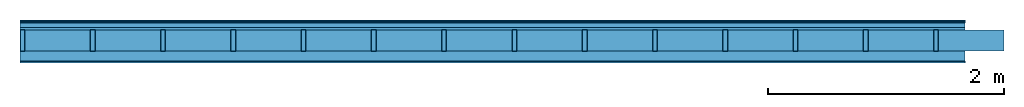
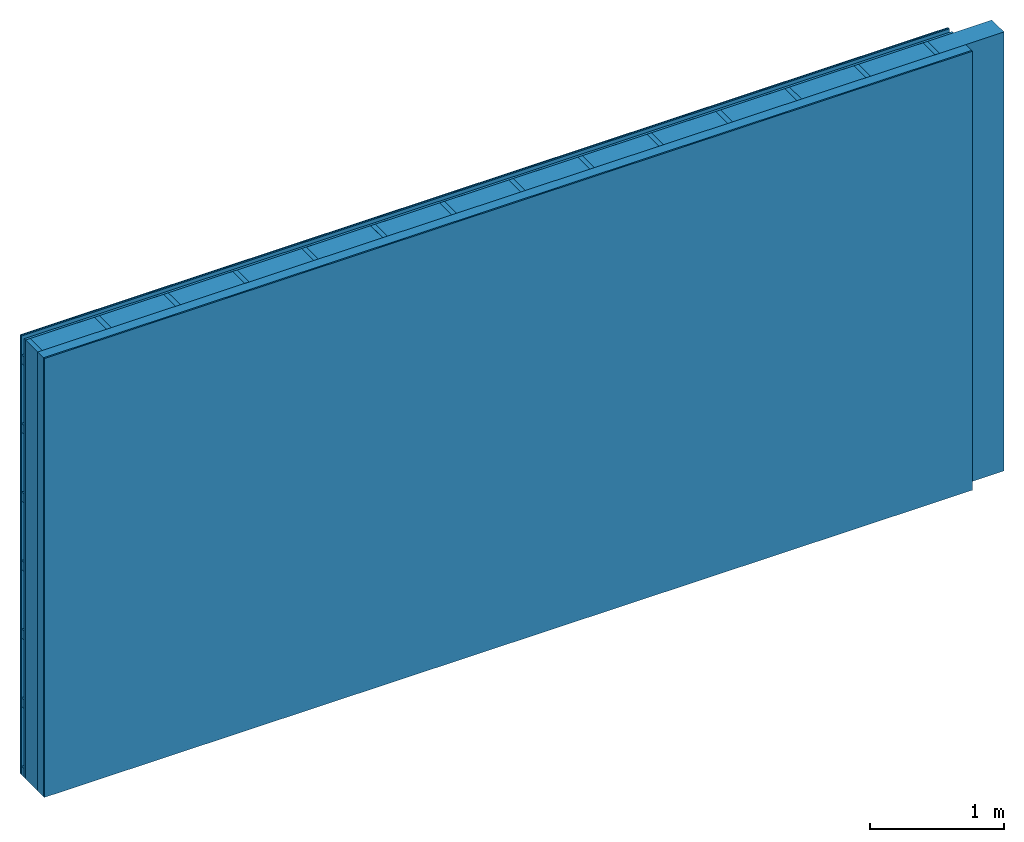
# One storey: 5 plates, 3 members, 1 element without a shape of its own.
"""IFC4 building model written with IfcOpenShell, lengths in metres."""

from ifc_helpers import new_model, si_unit, derived_unit, direction, frame, frame_2d, origin, origin_with_axes, place, context, project, spatial, rectangle, extrude, material, layer, layer_set, type_object, element, aggregate, save


model = new_model("IFC4")

# Units and contexts
plan_context = context("Plan", 3, precision=1e-05, world=origin(), true_north=direction((0.0, 1.0)))
model_context = context("Model", 3, precision=1e-05, world=origin(), true_north=direction((0.0, 1.0)))
ifc_project = project(units=[si_unit("LENGTHUNIT", "METRE"), derived_unit("SOUNDPRESSUREUNIT", [(si_unit("PRESSUREUNIT", "PASCAL", prefix="MICRO"), 0)]), si_unit("ENERGYUNIT", "JOULE", prefix="MEGA"), si_unit("MASSUNIT", "GRAM", prefix="KILO"), derived_unit("THERMALTRANSMITTANCEUNIT", [(si_unit("POWERUNIT", "WATT"), 1), (si_unit("AREAUNIT", "SQUARE_METRE"), -1), (si_unit("THERMODYNAMICTEMPERATUREUNIT", "KELVIN"), -1)]), derived_unit("AREADENSITYUNIT", [(si_unit("MASSUNIT", "GRAM", prefix="KILO"), 1), (si_unit("AREAUNIT", "SQUARE_METRE"), -1)]), derived_unit("USERDEFINED", [(si_unit("ENERGYUNIT", "JOULE", prefix="MEGA"), 1), (si_unit("AREAUNIT", "SQUARE_METRE"), -1)])], contexts=[plan_context, model_context])

# Site, building, storey
site = spatial("IfcSite", under=ifc_project)
building_placement = place(None, origin())
building = spatial("IfcBuilding", under=site, at=building_placement)
storey_placement = place(building_placement, origin())
storey = spatial("IfcBuildingStorey", under=building, at=storey_placement)

# Wall, members, plates
ifc_material_1 = material(Category="04.011")
ifc_layer_1 = layer(ifc_material_1, 0.01, Name="Surface 1")
ifc_material_2 = material(Name="mineral, cement-based building board", Category="03.003")
ifc_layer_2 = layer(ifc_material_2, 0.013, Name="Cover 1st layer")
ifc_layer_3 = layer(None, 0.04, Name="Battens / profiles (ventilation)")
ifc_material_3 = material(Category="10.009")
ifc_layer_4 = layer(ifc_material_3, 0.02, Name="outside 1st layer")
ifc_material_4 = material(Name="of the art")
ifc_layer_5 = layer(ifc_material_4, 0.0, Name="Bond")
ifc_layer_6 = layer(None, 0.18, Name="Support")
ifc_layer_7 = layer(ifc_material_4, 0.0, Name="Bond")
ifc_material_5 = material(Name="Solid timber panel")
ifc_layer_8 = layer(ifc_material_5, 0.087, Name="1st layer")
ifc_material_6 = material(Name="Plasterboard type A", Category="03.008")
ifc_layer_9 = layer(ifc_material_6, 0.0125, Name="Covering 1st layer")
ifc_material_7 = material(Name="joints", Category="04.017")
ifc_layer_10 = layer(ifc_material_7, 0.0, Name="Surface")
ifc_layer_set = layer_set([ifc_layer_1, ifc_layer_2, ifc_layer_3, ifc_layer_4, ifc_layer_5, ifc_layer_6, ifc_layer_7, ifc_layer_8, ifc_layer_9, ifc_layer_10])
wall_type = type_object("IfcWallType", Name="D0975", PredefinedType="NOTDEFINED", material=ifc_layer_set)
wall_placement = place(None, frame((0.0, 0.0, 0.0), z_axis=(0.0, -1.0, 0.0), x_axis=(1.0, 0.0, 0.0)))
wall = element("IfcWall", 1, at=wall_placement, inside=storey, type_object=wall_type, material=ifc_layer_set, Name="Wall #1")
ifc_material_8 = material()
member_1_placement = place(wall_placement, origin())
member_1 = element("IfcMember", 2, at=member_1_placement, material=ifc_material_8, Name="Battens / profiles (ventilation)", context=plan_context, shape_type="SweptSolid", body=[
    extrude(rectangle(XDim=0.08, YDim=0.04, at=frame_2d((0.04, 0.02), x_axis=(1.0, 0.0))), frame((0.0, 0.0, 0.023), z_axis=(1.0, 0.0, 0.0), x_axis=(0.0, 1.0, 0.0)), (0.0, 0.0, 1.0), 8.0),
    extrude(rectangle(XDim=0.08, YDim=0.04, at=frame_2d((0.04, 0.02), x_axis=(1.0, 0.0))), frame((0.0, 0.625, 0.023), z_axis=(1.0, 0.0, 0.0), x_axis=(0.0, 1.0, 0.0)), (0.0, 0.0, 1.0), 8.0),
    extrude(rectangle(XDim=0.08, YDim=0.04, at=frame_2d((0.04, 0.02), x_axis=(1.0, 0.0))), frame((0.0, 1.25, 0.023), z_axis=(1.0, 0.0, 0.0), x_axis=(0.0, 1.0, 0.0)), (0.0, 0.0, 1.0), 8.0),
    extrude(rectangle(XDim=0.08, YDim=0.04, at=frame_2d((0.04, 0.02), x_axis=(1.0, 0.0))), frame((0.0, 1.875, 0.023), z_axis=(1.0, 0.0, 0.0), x_axis=(0.0, 1.0, 0.0)), (0.0, 0.0, 1.0), 8.0),
    extrude(rectangle(XDim=0.08, YDim=0.04, at=frame_2d((0.04, 0.02), x_axis=(1.0, 0.0))), frame((0.0, 2.5, 0.023), z_axis=(1.0, 0.0, 0.0), x_axis=(0.0, 1.0, 0.0)), (0.0, 0.0, 1.0), 8.0),
    extrude(rectangle(XDim=0.08, YDim=0.04, at=frame_2d((0.04, 0.02), x_axis=(1.0, 0.0))), frame((0.0, 3.125, 0.023), z_axis=(1.0, 0.0, 0.0), x_axis=(0.0, 1.0, 0.0)), (0.0, 0.0, 1.0), 8.0),
    extrude(rectangle(XDim=0.08, YDim=0.04, at=frame_2d((0.04, 0.02), x_axis=(1.0, 0.0))), frame((0.0, 3.75, 0.023), z_axis=(1.0, 0.0, 0.0), x_axis=(0.0, 1.0, 0.0)), (0.0, 0.0, 1.0), 8.0),
])
ifc_material_9 = material()
member_2_placement = place(wall_placement, origin())
member_2 = element("IfcMember", 3, at=member_2_placement, material=ifc_material_9, Name="Support", context=plan_context, shape_type="SweptSolid", body=[
    extrude(rectangle(XDim=0.04, YDim=0.18, at=frame_2d((0.02, 0.09), x_axis=(1.0, 0.0))), frame((0.0, 4.0, 0.083), z_axis=(0.0, -1.0, 0.0), x_axis=(1.0, 0.0, 0.0)), (0.0, 0.0, 1.0), 4.0),
    extrude(rectangle(XDim=0.04, YDim=0.18, at=frame_2d((0.02, 0.09), x_axis=(1.0, 0.0))), frame((0.595, 4.0, 0.083), z_axis=(0.0, -1.0, 0.0), x_axis=(1.0, 0.0, 0.0)), (0.0, 0.0, 1.0), 4.0),
    extrude(rectangle(XDim=0.04, YDim=0.18, at=frame_2d((0.02, 0.09), x_axis=(1.0, 0.0))), frame((1.19, 4.0, 0.083), z_axis=(0.0, -1.0, 0.0), x_axis=(1.0, 0.0, 0.0)), (0.0, 0.0, 1.0), 4.0),
    extrude(rectangle(XDim=0.04, YDim=0.18, at=frame_2d((0.02, 0.09), x_axis=(1.0, 0.0))), frame((1.785, 4.0, 0.083), z_axis=(0.0, -1.0, 0.0), x_axis=(1.0, 0.0, 0.0)), (0.0, 0.0, 1.0), 4.0),
    extrude(rectangle(XDim=0.04, YDim=0.18, at=frame_2d((0.02, 0.09), x_axis=(1.0, 0.0))), frame((2.38, 4.0, 0.083), z_axis=(0.0, -1.0, 0.0), x_axis=(1.0, 0.0, 0.0)), (0.0, 0.0, 1.0), 4.0),
    extrude(rectangle(XDim=0.04, YDim=0.18, at=frame_2d((0.02, 0.09), x_axis=(1.0, 0.0))), frame((2.975, 4.0, 0.083), z_axis=(0.0, -1.0, 0.0), x_axis=(1.0, 0.0, 0.0)), (0.0, 0.0, 1.0), 4.0),
    extrude(rectangle(XDim=0.04, YDim=0.18, at=frame_2d((0.02, 0.09), x_axis=(1.0, 0.0))), frame((3.57, 4.0, 0.083), z_axis=(0.0, -1.0, 0.0), x_axis=(1.0, 0.0, 0.0)), (0.0, 0.0, 1.0), 4.0),
    extrude(rectangle(XDim=0.04, YDim=0.18, at=frame_2d((0.02, 0.09), x_axis=(1.0, 0.0))), frame((4.165, 4.0, 0.083), z_axis=(0.0, -1.0, 0.0), x_axis=(1.0, 0.0, 0.0)), (0.0, 0.0, 1.0), 4.0),
    extrude(rectangle(XDim=0.04, YDim=0.18, at=frame_2d((0.02, 0.09), x_axis=(1.0, 0.0))), frame((4.76, 4.0, 0.083), z_axis=(0.0, -1.0, 0.0), x_axis=(1.0, 0.0, 0.0)), (0.0, 0.0, 1.0), 4.0),
    extrude(rectangle(XDim=0.04, YDim=0.18, at=frame_2d((0.02, 0.09), x_axis=(1.0, 0.0))), frame((5.355, 4.0, 0.083), z_axis=(0.0, -1.0, 0.0), x_axis=(1.0, 0.0, 0.0)), (0.0, 0.0, 1.0), 4.0),
    extrude(rectangle(XDim=0.04, YDim=0.18, at=frame_2d((0.02, 0.09), x_axis=(1.0, 0.0))), frame((5.95, 4.0, 0.083), z_axis=(0.0, -1.0, 0.0), x_axis=(1.0, 0.0, 0.0)), (0.0, 0.0, 1.0), 4.0),
    extrude(rectangle(XDim=0.04, YDim=0.18, at=frame_2d((0.02, 0.09), x_axis=(1.0, 0.0))), frame((6.545, 4.0, 0.083), z_axis=(0.0, -1.0, 0.0), x_axis=(1.0, 0.0, 0.0)), (0.0, 0.0, 1.0), 4.0),
    extrude(rectangle(XDim=0.04, YDim=0.18, at=frame_2d((0.02, 0.09), x_axis=(1.0, 0.0))), frame((7.14, 4.0, 0.083), z_axis=(0.0, -1.0, 0.0), x_axis=(1.0, 0.0, 0.0)), (0.0, 0.0, 1.0), 4.0),
    extrude(rectangle(XDim=0.04, YDim=0.18, at=frame_2d((0.02, 0.09), x_axis=(1.0, 0.0))), frame((7.735, 4.0, 0.083), z_axis=(0.0, -1.0, 0.0), x_axis=(1.0, 0.0, 0.0)), (0.0, 0.0, 1.0), 4.0),
])
ifc_material_10 = material()
member_3_placement = place(wall_placement, origin())
member_3 = element("IfcMember", 4, at=member_3_placement, material=ifc_material_10, Name="Cavity", context=plan_context, shape_type="SweptSolid", body=[
    extrude(rectangle(XDim=0.555, YDim=0.18, at=frame_2d((0.2775, 0.09), x_axis=(1.0, 0.0))), frame((0.04, 4.0, 0.083), z_axis=(0.0, -1.0, 0.0), x_axis=(1.0, 0.0, 0.0)), (0.0, 0.0, 1.0), 4.0),
    extrude(rectangle(XDim=0.555, YDim=0.18, at=frame_2d((0.2775, 0.09), x_axis=(1.0, 0.0))), frame((0.635, 4.0, 0.083), z_axis=(0.0, -1.0, 0.0), x_axis=(1.0, 0.0, 0.0)), (0.0, 0.0, 1.0), 4.0),
    extrude(rectangle(XDim=0.555, YDim=0.18, at=frame_2d((0.2775, 0.09), x_axis=(1.0, 0.0))), frame((1.23, 4.0, 0.083), z_axis=(0.0, -1.0, 0.0), x_axis=(1.0, 0.0, 0.0)), (0.0, 0.0, 1.0), 4.0),
    extrude(rectangle(XDim=0.555, YDim=0.18, at=frame_2d((0.2775, 0.09), x_axis=(1.0, 0.0))), frame((1.825, 4.0, 0.083), z_axis=(0.0, -1.0, 0.0), x_axis=(1.0, 0.0, 0.0)), (0.0, 0.0, 1.0), 4.0),
    extrude(rectangle(XDim=0.555, YDim=0.18, at=frame_2d((0.2775, 0.09), x_axis=(1.0, 0.0))), frame((2.42, 4.0, 0.083), z_axis=(0.0, -1.0, 0.0), x_axis=(1.0, 0.0, 0.0)), (0.0, 0.0, 1.0), 4.0),
    extrude(rectangle(XDim=0.555, YDim=0.18, at=frame_2d((0.2775, 0.09), x_axis=(1.0, 0.0))), frame((3.015, 4.0, 0.083), z_axis=(0.0, -1.0, 0.0), x_axis=(1.0, 0.0, 0.0)), (0.0, 0.0, 1.0), 4.0),
    extrude(rectangle(XDim=0.555, YDim=0.18, at=frame_2d((0.2775, 0.09), x_axis=(1.0, 0.0))), frame((3.61, 4.0, 0.083), z_axis=(0.0, -1.0, 0.0), x_axis=(1.0, 0.0, 0.0)), (0.0, 0.0, 1.0), 4.0),
    extrude(rectangle(XDim=0.555, YDim=0.18, at=frame_2d((0.2775, 0.09), x_axis=(1.0, 0.0))), frame((4.205, 4.0, 0.083), z_axis=(0.0, -1.0, 0.0), x_axis=(1.0, 0.0, 0.0)), (0.0, 0.0, 1.0), 4.0),
    extrude(rectangle(XDim=0.555, YDim=0.18, at=frame_2d((0.2775, 0.09), x_axis=(1.0, 0.0))), frame((4.8, 4.0, 0.083), z_axis=(0.0, -1.0, 0.0), x_axis=(1.0, 0.0, 0.0)), (0.0, 0.0, 1.0), 4.0),
    extrude(rectangle(XDim=0.555, YDim=0.18, at=frame_2d((0.2775, 0.09), x_axis=(1.0, 0.0))), frame((5.395, 4.0, 0.083), z_axis=(0.0, -1.0, 0.0), x_axis=(1.0, 0.0, 0.0)), (0.0, 0.0, 1.0), 4.0),
    extrude(rectangle(XDim=0.555, YDim=0.18, at=frame_2d((0.2775, 0.09), x_axis=(1.0, 0.0))), frame((5.99, 4.0, 0.083), z_axis=(0.0, -1.0, 0.0), x_axis=(1.0, 0.0, 0.0)), (0.0, 0.0, 1.0), 4.0),
    extrude(rectangle(XDim=0.555, YDim=0.18, at=frame_2d((0.2775, 0.09), x_axis=(1.0, 0.0))), frame((6.585, 4.0, 0.083), z_axis=(0.0, -1.0, 0.0), x_axis=(1.0, 0.0, 0.0)), (0.0, 0.0, 1.0), 4.0),
    extrude(rectangle(XDim=0.555, YDim=0.18, at=frame_2d((0.2775, 0.09), x_axis=(1.0, 0.0))), frame((7.18, 4.0, 0.083), z_axis=(0.0, -1.0, 0.0), x_axis=(1.0, 0.0, 0.0)), (0.0, 0.0, 1.0), 4.0),
    extrude(rectangle(XDim=0.555, YDim=0.18, at=frame_2d((0.2775, 0.09), x_axis=(1.0, 0.0))), frame((7.775, 4.0, 0.083), z_axis=(0.0, -1.0, 0.0), x_axis=(1.0, 0.0, 0.0)), (0.0, 0.0, 1.0), 4.0),
])
plate_1_placement = place(wall_placement, origin())
plate_1 = element("IfcPlate", 5, at=plate_1_placement, material=ifc_material_1, Name="Surface 1", context=plan_context, shape_type="SweptSolid", body=[
    extrude(rectangle(XDim=8.0, YDim=4.0, at=frame_2d((4.0, 2.0), x_axis=(1.0, 0.0))), origin_with_axes(), (0.0, 0.0, 1.0), 0.01),
])
plate_2_placement = place(wall_placement, origin())
plate_2 = element("IfcPlate", 6, at=plate_2_placement, material=ifc_material_2, Name="Cover 1st layer", context=plan_context, shape_type="SweptSolid", body=[
    extrude(rectangle(XDim=8.0, YDim=4.0, at=frame_2d((4.0, 2.0), x_axis=(1.0, 0.0))), frame((0.0, 0.0, 0.01), z_axis=(0.0, 0.0, 1.0), x_axis=(1.0, 0.0, 0.0)), (0.0, 0.0, 1.0), 0.013),
])
plate_3_placement = place(wall_placement, origin())
plate_3 = element("IfcPlate", 7, at=plate_3_placement, material=ifc_material_3, Name="outside 1st layer", context=plan_context, shape_type="SweptSolid", body=[
    extrude(rectangle(XDim=8.0, YDim=4.0, at=frame_2d((4.0, 2.0), x_axis=(1.0, 0.0))), frame((0.0, 0.0, 0.063), z_axis=(0.0, 0.0, 1.0), x_axis=(1.0, 0.0, 0.0)), (0.0, 0.0, 1.0), 0.02),
])
plate_4_placement = place(wall_placement, origin())
plate_4 = element("IfcPlate", 8, at=plate_4_placement, material=ifc_material_5, Name="1st layer", context=plan_context, shape_type="SweptSolid", body=[
    extrude(rectangle(XDim=8.0, YDim=4.0, at=frame_2d((4.0, 2.0), x_axis=(1.0, 0.0))), frame((0.0, 0.0, 0.263), z_axis=(0.0, 0.0, 1.0), x_axis=(1.0, 0.0, 0.0)), (0.0, 0.0, 1.0), 0.087),
])
plate_5_placement = place(wall_placement, origin())
plate_5 = element("IfcPlate", 9, at=plate_5_placement, material=ifc_material_6, Name="Covering 1st layer", context=plan_context, shape_type="SweptSolid", body=[
    extrude(rectangle(XDim=8.0, YDim=4.0, at=frame_2d((4.0, 2.0), x_axis=(1.0, 0.0))), frame((0.0, 0.0, 0.35), z_axis=(0.0, 0.0, 1.0), x_axis=(1.0, 0.0, 0.0)), (0.0, 0.0, 1.0), 0.0125),
])
aggregate(wall, [plate_1, plate_2, member_1, plate_3, member_2, member_3, plate_4, plate_5])

save(model, "model.ifc")
